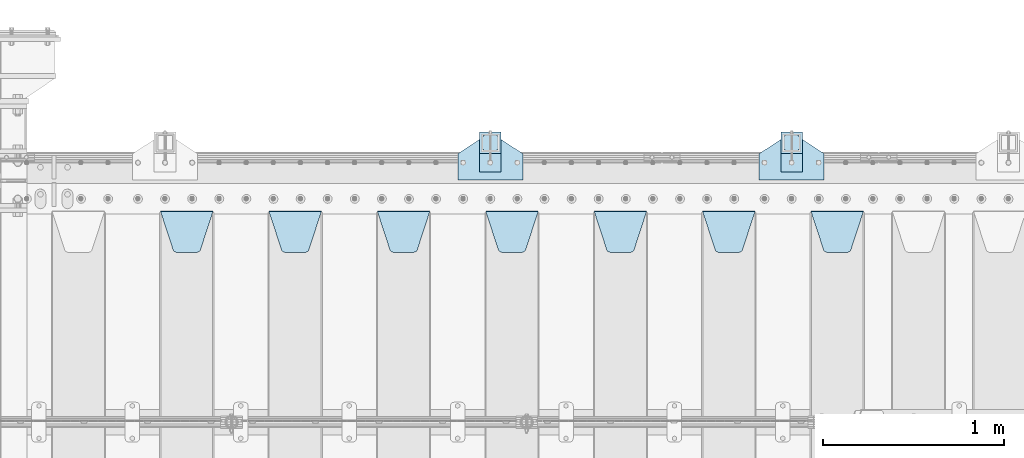
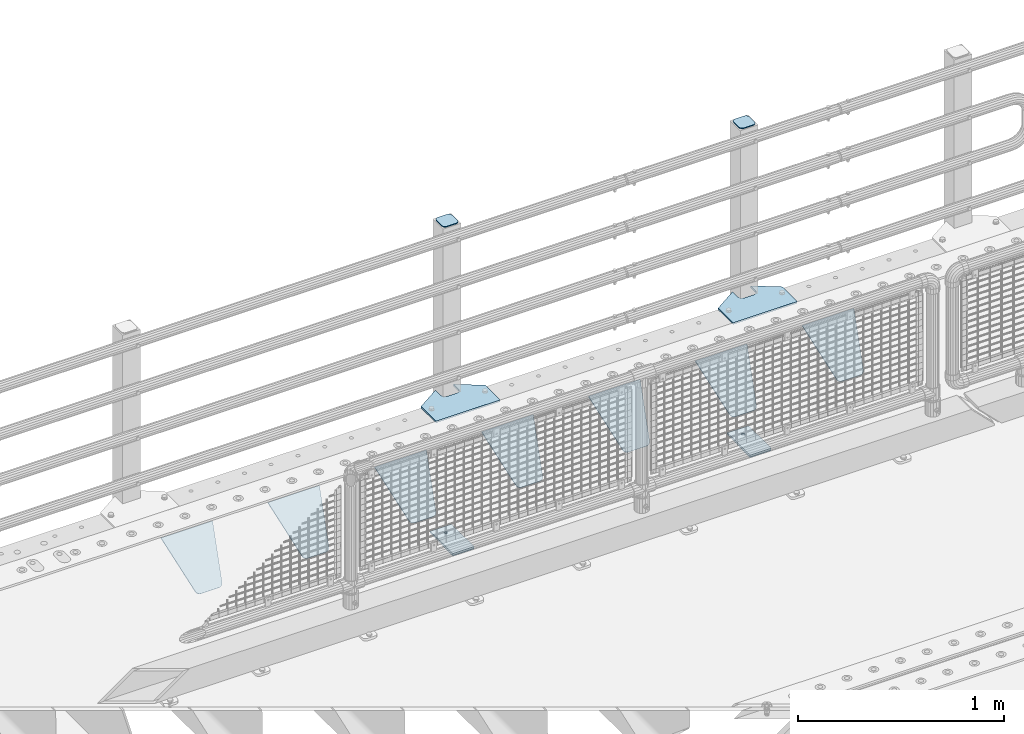
# One storey, part 224 of 242: 15 plates.
"""IFC2X3 building model written with IfcOpenShell, lengths in millimetres."""

from ifc_helpers import new_model, si_unit, frame, origin_with_axes, place, context, subcontext, project, spatial, faceted_brep, material, type_object, element, save


model = new_model("IFC2X3")

# Units and contexts
model_context = context("Model", 3, precision=1e-05, world=origin_with_axes())
body_context = subcontext(model_context, "Body", "Model", "MODEL_VIEW")
ifc_project = project(units=[si_unit("LENGTHUNIT", "METRE", prefix="MILLI"), si_unit("AREAUNIT", "SQUARE_METRE"), si_unit("VOLUMEUNIT", "CUBIC_METRE"), si_unit("MASSUNIT", "GRAM", prefix="KILO"), si_unit("TIMEUNIT", "SECOND"), si_unit("PLANEANGLEUNIT", "RADIAN"), si_unit("SOLIDANGLEUNIT", "STERADIAN"), si_unit("THERMODYNAMICTEMPERATUREUNIT", "DEGREE_CELSIUS"), si_unit("LUMINOUSINTENSITYUNIT", "LUMEN")], contexts=[model_context])

# Site, building, storey
site_placement = place(None, origin_with_axes())
site = spatial("IfcSite", under=ifc_project, at=site_placement, CompositionType="ELEMENT")
building_placement = place(site_placement, origin_with_axes())
building = spatial("IfcBuilding", under=site, at=building_placement, Name="Standard", CompositionType="ELEMENT")
storey_placement = place(building_placement, origin_with_axes())
storey = spatial("IfcBuildingStorey", under=building, at=storey_placement, Name="Undefined", CompositionType="ELEMENT", Elevation=0.0)

# Plates
ifc_material_1 = material(Name="STEEL/S355J2")
plate_type_1 = type_object("IfcPlateType", PredefinedType="NOTDEFINED")
plate_1_placement = place(storey_placement, frame((-24212.0, -17995.0, 5.00000000004911), z_axis=(0.0, 1.0, 0.0), x_axis=(1.0, 0.0, 0.0)))
element("IfcPlate", 1, at=plate_1_placement, inside=storey, type_object=plate_type_1, material=ifc_material_1, context=body_context, shape_type="Brep", body=[
    faceted_brep([(0.0, -5.0, 0.0), (2.31396552408114e-06, -5.0, 145.0), (2.31396552408114e-06, 5.0, 145.0), (0.0, 5.0, 0.0), (130.0, -5.0, 230.0), (130.0, 5.0, 230.0), (130.0, -5.0, 180.0), (130.0, 5.0, 180.0), (130.48036798992, -5.0, 175.122741949595), (130.48036798992, 5.0, 175.122741949595), (131.903011687216, -5.0, 170.432914190871), (131.903011687216, 5.0, 170.432914190871), (134.213259692435, -5.0, 166.110744174512), (134.213259692435, 5.0, 166.110744174512), (137.322330470335, -5.0, 162.322330470335), (137.322330470335, 5.0, 162.322330470335), (141.110744174512, -5.0, 159.213259692435), (141.110744174512, 5.0, 159.213259692435), (145.432914190871, -5.0, 156.903011687216), (145.432914190871, 5.0, 156.903011687216), (150.122741949595, -5.0, 155.48036798992), (150.122741949595, 5.0, 155.48036798992), (155.0, -5.0, 155.0), (155.0, 5.0, 155.0), (205.0, -5.0, 155.0), (205.0, 5.0, 155.0), (209.877258050405, -5.0, 155.48036798992), (209.877258050405, 5.0, 155.48036798992), (214.567085809129, -5.0, 156.903011687216), (214.567085809129, 5.0, 156.903011687216), (218.889255825488, -5.0, 159.213259692435), (218.889255825488, 5.0, 159.213259692435), (222.677669529665, -5.0, 162.322330470335), (222.677669529665, 5.0, 162.322330470335), (225.786740307565, -5.0, 166.110744174512), (225.786740307565, 5.0, 166.110744174512), (228.096988312784, -5.0, 170.432914190871), (228.096988312784, 5.0, 170.432914190871), (229.51963201008, -5.0, 175.122741949595), (229.51963201008, 5.0, 175.122741949595), (230.0, -5.0, 180.0), (230.0, 5.0, 180.0), (230.0, -5.0, 230.0), (230.0, 5.0, 230.0), (360.0, -5.0, 145.0), (360.0, 5.0, 145.0), (360.0, -5.0, -7.27595761418343e-12), (360.0, 5.0, -7.27595761418343e-12)], [[[0, 1, 2, 3]], [[1, 4, 5, 2]], [[4, 6, 7, 5]], [[6, 8, 9, 7]], [[8, 10, 11, 9]], [[10, 12, 13, 11]], [[12, 14, 15, 13]], [[14, 16, 17, 15]], [[16, 18, 19, 17]], [[18, 20, 21, 19]], [[20, 22, 23, 21]], [[22, 24, 25, 23]], [[24, 26, 27, 25]], [[26, 28, 29, 27]], [[28, 30, 31, 29]], [[30, 32, 33, 31]], [[32, 34, 35, 33]], [[34, 36, 37, 35]], [[36, 38, 39, 37]], [[38, 40, 41, 39]], [[40, 42, 43, 41]], [[42, 44, 45, 43]], [[44, 46, 47, 45]], [[46, 0, 3, 47]], [[5, 7, 9, 11, 13, 15, 17, 19, 21, 23, 25, 27, 29, 31, 33, 35, 37, 39, 41, 43, 45, 47, 3, 2]], [[46, 44, 42, 40, 38, 36, 34, 32, 30, 28, 26, 24, 22, 20, 18, 16, 14, 12, 10, 8, 6, 4, 1, 0]]]),
])
plate_2_placement = place(storey_placement, frame((-25880.0, -17995.0, 5.00000000004911), z_axis=(0.0, 1.0, 0.0), x_axis=(1.0, 0.0, 0.0)))
element("IfcPlate", 2, at=plate_2_placement, inside=storey, type_object=plate_type_1, material=ifc_material_1, context=body_context, shape_type="Brep", body=[
    faceted_brep([(0.0, -5.0, 0.0), (2.31396552408114e-06, -5.0, 145.0), (2.31396552408114e-06, 5.0, 145.0), (0.0, 5.0, 0.0), (130.0, -5.0, 230.0), (130.0, 5.0, 230.0), (130.0, -5.0, 180.0), (130.0, 5.0, 180.0), (130.48036798992, -5.0, 175.122741949595), (130.48036798992, 5.0, 175.122741949595), (131.903011687216, -5.0, 170.432914190871), (131.903011687216, 5.0, 170.432914190871), (134.213259692435, -5.0, 166.110744174512), (134.213259692435, 5.0, 166.110744174512), (137.322330470335, -5.0, 162.322330470335), (137.322330470335, 5.0, 162.322330470335), (141.110744174512, -5.0, 159.213259692435), (141.110744174512, 5.0, 159.213259692435), (145.432914190871, -5.0, 156.903011687216), (145.432914190871, 5.0, 156.903011687216), (150.122741949595, -5.0, 155.48036798992), (150.122741949595, 5.0, 155.48036798992), (155.0, -5.0, 155.0), (155.0, 5.0, 155.0), (205.0, -5.0, 155.0), (205.0, 5.0, 155.0), (209.877258050405, -5.0, 155.48036798992), (209.877258050405, 5.0, 155.48036798992), (214.567085809129, -5.0, 156.903011687216), (214.567085809129, 5.0, 156.903011687216), (218.889255825488, -5.0, 159.213259692435), (218.889255825488, 5.0, 159.213259692435), (222.677669529665, -5.0, 162.322330470335), (222.677669529665, 5.0, 162.322330470335), (225.786740307565, -5.0, 166.110744174512), (225.786740307565, 5.0, 166.110744174512), (228.096988312784, -5.0, 170.432914190871), (228.096988312784, 5.0, 170.432914190871), (229.51963201008, -5.0, 175.122741949595), (229.51963201008, 5.0, 175.122741949595), (230.0, -5.0, 180.0), (230.0, 5.0, 180.0), (230.0, -5.0, 230.0), (230.0, 5.0, 230.0), (360.0, -5.0, 145.0), (360.0, 5.0, 145.0), (360.0, -5.0, -7.27595761418343e-12), (360.0, 5.0, -7.27595761418343e-12)], [[[0, 1, 2, 3]], [[1, 4, 5, 2]], [[4, 6, 7, 5]], [[6, 8, 9, 7]], [[8, 10, 11, 9]], [[10, 12, 13, 11]], [[12, 14, 15, 13]], [[14, 16, 17, 15]], [[16, 18, 19, 17]], [[18, 20, 21, 19]], [[20, 22, 23, 21]], [[22, 24, 25, 23]], [[24, 26, 27, 25]], [[26, 28, 29, 27]], [[28, 30, 31, 29]], [[30, 32, 33, 31]], [[32, 34, 35, 33]], [[34, 36, 37, 35]], [[36, 38, 39, 37]], [[38, 40, 41, 39]], [[40, 42, 43, 41]], [[42, 44, 45, 43]], [[44, 46, 47, 45]], [[46, 0, 3, 47]], [[5, 7, 9, 11, 13, 15, 17, 19, 21, 23, 25, 27, 29, 31, 33, 35, 37, 39, 41, 43, 45, 47, 3, 2]], [[46, 44, 42, 40, 38, 36, 34, 32, 30, 28, 26, 24, 22, 20, 18, 16, 14, 12, 10, 8, 6, 4, 1, 0]]]),
])
plate_type_2 = type_object("IfcPlateType", PredefinedType="NOTDEFINED")
for number, where, z_axis, x_axis in (
    (3, (-24091.9999999999, -17949.9999999998, -850.000000000002), (0.0, 1.0, 0.0), (1.0, 0.0, 0.0)),
    (4, (-25759.9999999999, -17949.9999999998, -850.000000000002), (0.0, 1.0, 0.0), (1.0, 0.0, 0.0)),
):
    element("IfcPlate", number, at=place(storey_placement, frame(where, z_axis=z_axis, x_axis=x_axis)), inside=storey, type_object=plate_type_2, material=ifc_material_1, context=body_context, shape_type="Brep", body=[
        faceted_brep([(66.3639610305399, -5.0, 163.636038969114), (66.3639610305399, 5.0, 163.636038969114), (59.9999999998618, 5.0, 160.999999999793), (59.9999999998618, -5.0, 160.999999999793), (53.6360389691836, 5.0, 163.636038969114), (53.6360389691836, -5.0, 163.636038969114), (50.9999999998618, 5.0, 169.999999999793), (50.9999999998618, -5.0, 169.999999999793), (53.6360389691836, 5.0, 176.363961030471), (53.6360389691836, -5.0, 176.363961030471), (59.9999999998618, 5.0, 178.999999999793), (59.9999999998618, -5.0, 178.999999999793), (66.3639610305399, 5.0, 176.363961030471), (66.3639610305399, -5.0, 176.363961030471), (68.9999999998618, 5.0, 169.999999999793), (68.9999999998618, -5.0, 169.999999999793), (120.0, -5.0, 0.0), (120.0, -5.0, 220.0), (0.0, -5.0, 220.0), (0.0, -5.0, 0.0), (0.0, 5.0, 0.0), (120.0, 5.0, 0.0), (120.0, 5.0, 220.0), (0.0, 5.0, 220.0)], [[[0, 1, 2, 3]], [[3, 2, 4, 5]], [[5, 4, 6, 7]], [[7, 6, 8, 9]], [[9, 8, 10, 11]], [[11, 10, 12, 13]], [[13, 12, 14, 15]], [[15, 14, 1, 0]], [[16, 17, 18, 19], [11, 13, 15, 0, 3, 5, 7, 9]], [[16, 19, 20, 21]], [[17, 16, 21, 22]], [[18, 17, 22, 23]], [[19, 18, 23, 20]], [[22, 21, 20, 23], [2, 1, 14, 12, 10, 8, 6, 4]]]),
    ])
plate_type_3 = type_object("IfcPlateType", PredefinedType="NOTDEFINED")
plate_3_placement = place(storey_placement, frame((-23987.9999999999, -17833.9999999998, 1012.50000000001), z_axis=(0.0, 1.0, 0.0), x_axis=(-1.0, 0.0, 0.0)))
element("IfcPlate", 5, at=plate_3_placement, inside=storey, type_object=plate_type_3, material=ifc_material_1, context=body_context, shape_type="Brep", body=[
    faceted_brep([(0.0, -2.5, 19.0), (0.0, -2.5, 69.0), (0.0, 2.5, 69.0), (0.0, 2.5, 19.0), (0.476369668544066, -2.5, 73.2278977451715), (0.476369668544066, 2.5, 73.2278977451715), (1.88159150985302, -2.5, 77.2437910432345), (1.88159150985302, 2.5, 77.2437910432345), (4.14520183310742, -2.5, 80.8463062353148), (4.14520183310742, 2.5, 80.8463062353148), (7.15369376468516, -2.5, 83.8547981668926), (7.15369376468516, 2.5, 83.8547981668926), (10.7562089567655, -2.5, 86.118408490147), (10.7562089567655, 2.5, 86.118408490147), (14.7721022548285, -2.5, 87.5236303314559), (14.7721022548285, 2.5, 87.5236303314559), (19.0, -2.5, 88.0), (19.0, 2.5, 88.0), (69.0, -2.5, 88.0), (69.0, 2.5, 88.0), (73.2278977451715, -2.5, 87.5236303314559), (73.2278977451715, 2.5, 87.5236303314559), (77.2437910432345, -2.5, 86.118408490147), (77.2437910432345, 2.5, 86.118408490147), (80.8463062353148, -2.5, 83.8547981668926), (80.8463062353148, 2.5, 83.8547981668926), (83.8547981668926, -2.5, 80.8463062353148), (83.8547981668926, 2.5, 80.8463062353148), (86.118408490147, -2.5, 77.2437910432345), (86.118408490147, 2.5, 77.2437910432345), (87.5236303314559, -2.5, 73.2278977451715), (87.5236303314559, 2.5, 73.2278977451715), (88.0, -2.5, 69.0), (88.0, 2.5, 69.0), (88.0, -2.5, 19.0), (88.0, 2.5, 19.0), (87.5236303314559, -2.5, 14.7721022548285), (87.5236303314559, 2.5, 14.7721022548285), (86.118408490147, -2.5, 10.7562089567655), (86.118408490147, 2.5, 10.7562089567655), (83.8547981668926, -2.5, 7.15369376468516), (83.8547981668926, 2.5, 7.15369376468516), (80.8463062353148, -2.5, 4.14520183310742), (80.8463062353148, 2.5, 4.14520183310742), (77.2437910432345, -2.5, 1.88159150985302), (77.2437910432345, 2.5, 1.88159150985302), (73.2278977451715, -2.5, 0.476369668544066), (73.2278977451715, 2.5, 0.476369668544066), (69.0, -2.5, 0.0), (69.0, 2.5, 0.0), (19.0, -2.5, 0.0), (19.0, 2.5, 0.0), (14.7721022548285, -2.5, 0.476369668544066), (14.7721022548285, 2.5, 0.476369668544066), (10.7562089567655, -2.5, 1.88159150985302), (10.7562089567655, 2.5, 1.88159150985302), (7.15369376468516, -2.5, 4.14520183310742), (7.15369376468516, 2.5, 4.14520183310742), (4.14520183310742, -2.5, 7.15369376468516), (4.14520183310742, 2.5, 7.15369376468516), (1.88159150985302, -2.5, 10.7562089567655), (1.88159150985302, 2.5, 10.7562089567655), (0.476369668544066, -2.5, 14.7721022548285), (0.476369668544066, 2.5, 14.7721022548285)], [[[0, 1, 2, 3]], [[1, 4, 5, 2]], [[4, 6, 7, 5]], [[6, 8, 9, 7]], [[8, 10, 11, 9]], [[10, 12, 13, 11]], [[12, 14, 15, 13]], [[14, 16, 17, 15]], [[16, 18, 19, 17]], [[18, 20, 21, 19]], [[20, 22, 23, 21]], [[22, 24, 25, 23]], [[24, 26, 27, 25]], [[26, 28, 29, 27]], [[28, 30, 31, 29]], [[30, 32, 33, 31]], [[32, 34, 35, 33]], [[34, 36, 37, 35]], [[36, 38, 39, 37]], [[38, 40, 41, 39]], [[40, 42, 43, 41]], [[42, 44, 45, 43]], [[44, 46, 47, 45]], [[46, 48, 49, 47]], [[48, 50, 51, 49]], [[50, 52, 53, 51]], [[52, 54, 55, 53]], [[54, 56, 57, 55]], [[56, 58, 59, 57]], [[58, 60, 61, 59]], [[60, 62, 63, 61]], [[62, 0, 3, 63]], [[5, 7, 9, 11, 13, 15, 17, 19, 21, 23, 25, 27, 29, 31, 33, 35, 37, 39, 41, 43, 45, 47, 49, 51, 53, 55, 57, 59, 61, 63, 3, 2]], [[62, 60, 58, 56, 54, 52, 50, 48, 46, 44, 42, 40, 38, 36, 34, 32, 30, 28, 26, 24, 22, 20, 18, 16, 14, 12, 10, 8, 6, 4, 1, 0]]]),
])
plate_4_placement = place(storey_placement, frame((-25655.9999999999, -17833.9999999998, 1012.50000000001), z_axis=(0.0, 1.0, 0.0), x_axis=(-1.0, 0.0, 0.0)))
element("IfcPlate", 6, at=plate_4_placement, inside=storey, type_object=plate_type_3, material=ifc_material_1, context=body_context, shape_type="Brep", body=[
    faceted_brep([(0.0, -2.5, 19.0), (0.0, -2.5, 69.0), (0.0, 2.5, 69.0), (0.0, 2.5, 19.0), (0.476369668544066, -2.5, 73.2278977451715), (0.476369668544066, 2.5, 73.2278977451715), (1.88159150985302, -2.5, 77.2437910432345), (1.88159150985302, 2.5, 77.2437910432345), (4.14520183310742, -2.5, 80.8463062353148), (4.14520183310742, 2.5, 80.8463062353148), (7.15369376468516, -2.5, 83.8547981668926), (7.15369376468516, 2.5, 83.8547981668926), (10.7562089567655, -2.5, 86.118408490147), (10.7562089567655, 2.5, 86.118408490147), (14.7721022548285, -2.5, 87.5236303314559), (14.7721022548285, 2.5, 87.5236303314559), (19.0, -2.5, 88.0), (19.0, 2.5, 88.0), (69.0, -2.5, 88.0), (69.0, 2.5, 88.0), (73.2278977451715, -2.5, 87.5236303314559), (73.2278977451715, 2.5, 87.5236303314559), (77.2437910432345, -2.5, 86.118408490147), (77.2437910432345, 2.5, 86.118408490147), (80.8463062353148, -2.5, 83.8547981668926), (80.8463062353148, 2.5, 83.8547981668926), (83.8547981668926, -2.5, 80.8463062353148), (83.8547981668926, 2.5, 80.8463062353148), (86.118408490147, -2.5, 77.2437910432345), (86.118408490147, 2.5, 77.2437910432345), (87.5236303314559, -2.5, 73.2278977451715), (87.5236303314559, 2.5, 73.2278977451715), (88.0, -2.5, 69.0), (88.0, 2.5, 69.0), (88.0, -2.5, 19.0), (88.0, 2.5, 19.0), (87.5236303314559, -2.5, 14.7721022548285), (87.5236303314559, 2.5, 14.7721022548285), (86.118408490147, -2.5, 10.7562089567655), (86.118408490147, 2.5, 10.7562089567655), (83.8547981668926, -2.5, 7.15369376468516), (83.8547981668926, 2.5, 7.15369376468516), (80.8463062353148, -2.5, 4.14520183310742), (80.8463062353148, 2.5, 4.14520183310742), (77.2437910432345, -2.5, 1.88159150985302), (77.2437910432345, 2.5, 1.88159150985302), (73.2278977451715, -2.5, 0.476369668544066), (73.2278977451715, 2.5, 0.476369668544066), (69.0, -2.5, 0.0), (69.0, 2.5, 0.0), (19.0, -2.5, 0.0), (19.0, 2.5, 0.0), (14.7721022548285, -2.5, 0.476369668544066), (14.7721022548285, 2.5, 0.476369668544066), (10.7562089567655, -2.5, 1.88159150985302), (10.7562089567655, 2.5, 1.88159150985302), (7.15369376468516, -2.5, 4.14520183310742), (7.15369376468516, 2.5, 4.14520183310742), (4.14520183310742, -2.5, 7.15369376468516), (4.14520183310742, 2.5, 7.15369376468516), (1.88159150985302, -2.5, 10.7562089567655), (1.88159150985302, 2.5, 10.7562089567655), (0.476369668544066, -2.5, 14.7721022548285), (0.476369668544066, 2.5, 14.7721022548285)], [[[0, 1, 2, 3]], [[1, 4, 5, 2]], [[4, 6, 7, 5]], [[6, 8, 9, 7]], [[8, 10, 11, 9]], [[10, 12, 13, 11]], [[12, 14, 15, 13]], [[14, 16, 17, 15]], [[16, 18, 19, 17]], [[18, 20, 21, 19]], [[20, 22, 23, 21]], [[22, 24, 25, 23]], [[24, 26, 27, 25]], [[26, 28, 29, 27]], [[28, 30, 31, 29]], [[30, 32, 33, 31]], [[32, 34, 35, 33]], [[34, 36, 37, 35]], [[36, 38, 39, 37]], [[38, 40, 41, 39]], [[40, 42, 43, 41]], [[42, 44, 45, 43]], [[44, 46, 47, 45]], [[46, 48, 49, 47]], [[48, 50, 51, 49]], [[50, 52, 53, 51]], [[52, 54, 55, 53]], [[54, 56, 57, 55]], [[56, 58, 59, 57]], [[58, 60, 61, 59]], [[60, 62, 63, 61]], [[62, 0, 3, 63]], [[5, 7, 9, 11, 13, 15, 17, 19, 21, 23, 25, 27, 29, 31, 33, 35, 37, 39, 41, 43, 45, 47, 49, 51, 53, 55, 57, 59, 61, 63, 3, 2]], [[62, 60, 58, 56, 54, 52, 50, 48, 46, 44, 42, 40, 38, 36, 34, 32, 30, 28, 26, 24, 22, 20, 18, 16, 14, 12, 10, 8, 6, 4, 1, 0]]]),
])
plate_type_4 = type_object("IfcPlateType", PredefinedType="NOTDEFINED")
for number, where, z_axis, x_axis in (
    (7, (-24091.9999999999, -17949.9999999998, -857.500000000002), (0.0, 1.0, 0.0), (1.0, 0.0, 0.0)),
    (8, (-25759.9999999999, -17949.9999999998, -857.500000000002), (0.0, 1.0, 0.0), (1.0, 0.0, 0.0)),
):
    element("IfcPlate", number, at=place(storey_placement, frame(where, z_axis=z_axis, x_axis=x_axis)), inside=storey, type_object=plate_type_4, material=ifc_material_1, context=body_context, shape_type="Brep", body=[
        faceted_brep([(0.0, -2.5, 0.0), (0.0, -2.5, 100.0), (0.0, 2.5, 100.0), (0.0, 2.5, 0.0), (120.0, -2.5, 100.0), (120.0, 2.5, 100.0), (120.0, -2.5, 0.0), (120.0, 2.5, 0.0)], [[[0, 1, 2, 3]], [[1, 4, 5, 2]], [[4, 6, 7, 5]], [[6, 0, 3, 7]], [[5, 7, 3, 2]], [[6, 4, 1, 0]]]),
    ])
ifc_material_2 = material(Name="STEEL/S355N")
plate_type_5 = type_object("IfcPlateType", PredefinedType="NOTDEFINED")
plate_5_placement = place(storey_placement, frame((-23925.0, -18168.2322330441, -1.76776695296576), z_axis=(0.0, -0.707106781186547, -0.707106781186548), x_axis=(1.0, 0.0, 0.0)))
element("IfcPlate", 9, at=plate_5_placement, inside=storey, type_object=plate_type_5, material=ifc_material_2, context=body_context, shape_type="Brep", body=[
    faceted_brep([(0.0, -2.5, 0.0), (69.345504679477, -2.50000000000182, 300.171731424829), (69.345504679477, 2.5, 300.171731424829), (0.0, 2.5, 0.0), (70.9274061199576, -2.5, 304.897442415398), (70.9274061199576, 2.5, 304.897442415398), (73.3818627772307, -2.5, 309.234538108525), (73.3818627772307, 2.50000000000182, 309.234538108529), (76.6187032999551, -2.5, 313.023683126101), (76.6187032999551, 2.50000000000182, 313.023683126103), (80.5190132704993, -2.5, 316.12567259537), (80.5190132704993, 2.5, 316.12567259537), (84.9395038596849, -2.5, 318.426546230474), (84.9395038596849, 2.50000000000182, 318.426546230476), (89.7177759439219, -2.49999999999818, 319.841774983273), (89.7177759439219, 2.50000000000182, 319.841774983273), (94.678286292652, -2.5, 320.319366455076), (94.678286292652, 2.5, 320.319366455076), (195.321713707348, -2.5, 320.319366455076), (195.321713707348, 2.5, 320.319366455076), (200.282224056078, -2.5, 319.841774983272), (200.282224056078, 2.50000000000182, 319.841774983273), (205.060496140315, -2.5, 318.426546230474), (205.060496140315, 2.49999999999818, 318.426546230474), (209.480986729501, -2.49999999999818, 316.12567259537), (209.480986729501, 2.5, 316.12567259537), (213.381296700045, -2.5, 313.023683126101), (213.381296700045, 2.49999999999818, 313.023683126101), (216.618137222769, -2.5, 309.234538108525), (216.618137222769, 2.5, 309.234538108523), (219.072593880042, -2.49999999999818, 304.897442415398), (219.072593880042, 2.50000000000182, 304.897442415398), (220.654495320523, -2.50000000000182, 300.171731424829), (220.654495320523, 2.5, 300.171731424829), (290.0, -2.5, 0.0), (290.0, 2.5, -1.81898940354586e-12)], [[[0, 1, 2, 3]], [[1, 4, 5, 2]], [[4, 6, 7, 5]], [[6, 8, 9, 7]], [[8, 10, 11, 9]], [[10, 12, 13, 11]], [[12, 14, 15, 13]], [[14, 16, 17, 15]], [[16, 18, 19, 17]], [[18, 20, 21, 19]], [[20, 22, 23, 21]], [[22, 24, 25, 23]], [[24, 26, 27, 25]], [[26, 28, 29, 27]], [[28, 30, 31, 29]], [[30, 32, 33, 31]], [[32, 34, 35, 33]], [[34, 0, 3, 35]], [[5, 7, 9, 11, 13, 15, 17, 19, 21, 23, 25, 27, 29, 31, 33, 35, 3, 2]], [[34, 32, 30, 28, 26, 24, 22, 20, 18, 16, 14, 12, 10, 8, 6, 4, 1, 0]]]),
])
plate_6_placement = place(storey_placement, frame((-24525.0, -18168.2322330441, -1.76776695296576), z_axis=(0.0, -0.707106781186547, -0.707106781186548), x_axis=(1.0, 0.0, 0.0)))
element("IfcPlate", 10, at=plate_6_placement, inside=storey, type_object=plate_type_5, material=ifc_material_2, context=body_context, shape_type="Brep", body=[
    faceted_brep([(0.0, -2.5, 0.0), (69.345504679477, -2.50000000000182, 300.171731424829), (69.345504679477, 2.5, 300.171731424829), (0.0, 2.5, 0.0), (70.9274061199576, -2.5, 304.897442415398), (70.9274061199576, 2.5, 304.897442415398), (73.3818627772307, -2.5, 309.234538108525), (73.3818627772307, 2.50000000000182, 309.234538108529), (76.6187032999551, -2.5, 313.023683126101), (76.6187032999551, 2.50000000000182, 313.023683126103), (80.5190132704993, -2.5, 316.12567259537), (80.5190132704993, 2.5, 316.12567259537), (84.9395038596849, -2.5, 318.426546230474), (84.9395038596849, 2.50000000000182, 318.426546230476), (89.7177759439219, -2.49999999999818, 319.841774983273), (89.7177759439219, 2.50000000000182, 319.841774983273), (94.678286292652, -2.5, 320.319366455076), (94.678286292652, 2.5, 320.319366455076), (195.321713707348, -2.5, 320.319366455076), (195.321713707348, 2.5, 320.319366455076), (200.282224056078, -2.5, 319.841774983272), (200.282224056078, 2.50000000000182, 319.841774983273), (205.060496140315, -2.5, 318.426546230474), (205.060496140315, 2.49999999999818, 318.426546230474), (209.480986729501, -2.49999999999818, 316.12567259537), (209.480986729501, 2.5, 316.12567259537), (213.381296700045, -2.5, 313.023683126101), (213.381296700045, 2.49999999999818, 313.023683126101), (216.618137222769, -2.5, 309.234538108525), (216.618137222769, 2.5, 309.234538108523), (219.072593880042, -2.49999999999818, 304.897442415398), (219.072593880042, 2.50000000000182, 304.897442415398), (220.654495320523, -2.50000000000182, 300.171731424829), (220.654495320523, 2.5, 300.171731424829), (290.0, -2.5, 0.0), (290.0, 2.5, -1.81898940354586e-12)], [[[0, 1, 2, 3]], [[1, 4, 5, 2]], [[4, 6, 7, 5]], [[6, 8, 9, 7]], [[8, 10, 11, 9]], [[10, 12, 13, 11]], [[12, 14, 15, 13]], [[14, 16, 17, 15]], [[16, 18, 19, 17]], [[18, 20, 21, 19]], [[20, 22, 23, 21]], [[22, 24, 25, 23]], [[24, 26, 27, 25]], [[26, 28, 29, 27]], [[28, 30, 31, 29]], [[30, 32, 33, 31]], [[32, 34, 35, 33]], [[34, 0, 3, 35]], [[5, 7, 9, 11, 13, 15, 17, 19, 21, 23, 25, 27, 29, 31, 33, 35, 3, 2]], [[34, 32, 30, 28, 26, 24, 22, 20, 18, 16, 14, 12, 10, 8, 6, 4, 1, 0]]]),
])
plate_7_placement = place(storey_placement, frame((-25125.0, -18168.2322330441, -1.76776695296576), z_axis=(0.0, -0.707106781186547, -0.707106781186548), x_axis=(1.0, 0.0, 0.0)))
element("IfcPlate", 11, at=plate_7_placement, inside=storey, type_object=plate_type_5, material=ifc_material_2, context=body_context, shape_type="Brep", body=[
    faceted_brep([(0.0, -2.5, 0.0), (69.345504679477, -2.50000000000182, 300.171731424829), (69.345504679477, 2.5, 300.171731424829), (0.0, 2.5, 0.0), (70.9274061199576, -2.5, 304.897442415398), (70.9274061199576, 2.5, 304.897442415398), (73.3818627772307, -2.5, 309.234538108525), (73.3818627772307, 2.50000000000182, 309.234538108529), (76.6187032999551, -2.5, 313.023683126101), (76.6187032999551, 2.50000000000182, 313.023683126103), (80.5190132704993, -2.5, 316.12567259537), (80.5190132704993, 2.5, 316.12567259537), (84.9395038596849, -2.5, 318.426546230474), (84.9395038596849, 2.50000000000182, 318.426546230476), (89.7177759439219, -2.49999999999818, 319.841774983273), (89.7177759439219, 2.50000000000182, 319.841774983273), (94.678286292652, -2.5, 320.319366455076), (94.678286292652, 2.5, 320.319366455076), (195.321713707348, -2.5, 320.319366455076), (195.321713707348, 2.5, 320.319366455076), (200.282224056078, -2.5, 319.841774983272), (200.282224056078, 2.50000000000182, 319.841774983273), (205.060496140315, -2.5, 318.426546230474), (205.060496140315, 2.49999999999818, 318.426546230474), (209.480986729501, -2.49999999999818, 316.12567259537), (209.480986729501, 2.5, 316.12567259537), (213.381296700045, -2.5, 313.023683126101), (213.381296700045, 2.49999999999818, 313.023683126101), (216.618137222769, -2.5, 309.234538108525), (216.618137222769, 2.5, 309.234538108523), (219.072593880042, -2.49999999999818, 304.897442415398), (219.072593880042, 2.50000000000182, 304.897442415398), (220.654495320523, -2.50000000000182, 300.171731424829), (220.654495320523, 2.5, 300.171731424829), (290.0, -2.5, 0.0), (290.0, 2.5, -1.81898940354586e-12)], [[[0, 1, 2, 3]], [[1, 4, 5, 2]], [[4, 6, 7, 5]], [[6, 8, 9, 7]], [[8, 10, 11, 9]], [[10, 12, 13, 11]], [[12, 14, 15, 13]], [[14, 16, 17, 15]], [[16, 18, 19, 17]], [[18, 20, 21, 19]], [[20, 22, 23, 21]], [[22, 24, 25, 23]], [[24, 26, 27, 25]], [[26, 28, 29, 27]], [[28, 30, 31, 29]], [[30, 32, 33, 31]], [[32, 34, 35, 33]], [[34, 0, 3, 35]], [[5, 7, 9, 11, 13, 15, 17, 19, 21, 23, 25, 27, 29, 31, 33, 35, 3, 2]], [[34, 32, 30, 28, 26, 24, 22, 20, 18, 16, 14, 12, 10, 8, 6, 4, 1, 0]]]),
])
plate_8_placement = place(storey_placement, frame((-25725.0, -18168.2322330441, -1.76776695296576), z_axis=(0.0, -0.707106781186547, -0.707106781186548), x_axis=(1.0, 0.0, 0.0)))
element("IfcPlate", 12, at=plate_8_placement, inside=storey, type_object=plate_type_5, material=ifc_material_2, context=body_context, shape_type="Brep", body=[
    faceted_brep([(0.0, -2.5, 0.0), (69.345504679477, -2.50000000000182, 300.171731424829), (69.345504679477, 2.5, 300.171731424829), (0.0, 2.5, 0.0), (70.9274061199576, -2.5, 304.897442415398), (70.9274061199576, 2.5, 304.897442415398), (73.3818627772307, -2.5, 309.234538108525), (73.3818627772307, 2.50000000000182, 309.234538108529), (76.6187032999551, -2.5, 313.023683126101), (76.6187032999551, 2.50000000000182, 313.023683126103), (80.5190132704993, -2.5, 316.12567259537), (80.5190132704993, 2.5, 316.12567259537), (84.9395038596849, -2.5, 318.426546230474), (84.9395038596849, 2.50000000000182, 318.426546230476), (89.7177759439219, -2.49999999999818, 319.841774983273), (89.7177759439219, 2.50000000000182, 319.841774983273), (94.678286292652, -2.5, 320.319366455076), (94.678286292652, 2.5, 320.319366455076), (195.321713707348, -2.5, 320.319366455076), (195.321713707348, 2.5, 320.319366455076), (200.282224056078, -2.5, 319.841774983272), (200.282224056078, 2.50000000000182, 319.841774983273), (205.060496140315, -2.5, 318.426546230474), (205.060496140315, 2.49999999999818, 318.426546230474), (209.480986729501, -2.49999999999818, 316.12567259537), (209.480986729501, 2.5, 316.12567259537), (213.381296700045, -2.5, 313.023683126101), (213.381296700045, 2.49999999999818, 313.023683126101), (216.618137222769, -2.5, 309.234538108525), (216.618137222769, 2.5, 309.234538108523), (219.072593880042, -2.49999999999818, 304.897442415398), (219.072593880042, 2.50000000000182, 304.897442415398), (220.654495320523, -2.50000000000182, 300.171731424829), (220.654495320523, 2.5, 300.171731424829), (290.0, -2.5, 0.0), (290.0, 2.5, -1.81898940354586e-12)], [[[0, 1, 2, 3]], [[1, 4, 5, 2]], [[4, 6, 7, 5]], [[6, 8, 9, 7]], [[8, 10, 11, 9]], [[10, 12, 13, 11]], [[12, 14, 15, 13]], [[14, 16, 17, 15]], [[16, 18, 19, 17]], [[18, 20, 21, 19]], [[20, 22, 23, 21]], [[22, 24, 25, 23]], [[24, 26, 27, 25]], [[26, 28, 29, 27]], [[28, 30, 31, 29]], [[30, 32, 33, 31]], [[32, 34, 35, 33]], [[34, 0, 3, 35]], [[5, 7, 9, 11, 13, 15, 17, 19, 21, 23, 25, 27, 29, 31, 33, 35, 3, 2]], [[34, 32, 30, 28, 26, 24, 22, 20, 18, 16, 14, 12, 10, 8, 6, 4, 1, 0]]]),
])
plate_9_placement = place(storey_placement, frame((-26325.0, -18168.2322330441, -1.76776695296576), z_axis=(0.0, -0.707106781186547, -0.707106781186548), x_axis=(1.0, 0.0, 0.0)))
element("IfcPlate", 13, at=plate_9_placement, inside=storey, type_object=plate_type_5, material=ifc_material_2, context=body_context, shape_type="Brep", body=[
    faceted_brep([(0.0, -2.5, 0.0), (69.345504679477, -2.50000000000182, 300.171731424829), (69.345504679477, 2.5, 300.171731424829), (0.0, 2.5, 0.0), (70.9274061199576, -2.5, 304.897442415398), (70.9274061199576, 2.5, 304.897442415398), (73.3818627772307, -2.5, 309.234538108525), (73.3818627772307, 2.50000000000182, 309.234538108529), (76.6187032999551, -2.5, 313.023683126101), (76.6187032999551, 2.50000000000182, 313.023683126103), (80.5190132704993, -2.5, 316.12567259537), (80.5190132704993, 2.5, 316.12567259537), (84.9395038596849, -2.5, 318.426546230474), (84.9395038596849, 2.50000000000182, 318.426546230476), (89.7177759439219, -2.49999999999818, 319.841774983273), (89.7177759439219, 2.50000000000182, 319.841774983273), (94.678286292652, -2.5, 320.319366455076), (94.678286292652, 2.5, 320.319366455076), (195.321713707348, -2.5, 320.319366455076), (195.321713707348, 2.5, 320.319366455076), (200.282224056078, -2.5, 319.841774983272), (200.282224056078, 2.50000000000182, 319.841774983273), (205.060496140315, -2.5, 318.426546230474), (205.060496140315, 2.49999999999818, 318.426546230474), (209.480986729501, -2.49999999999818, 316.12567259537), (209.480986729501, 2.5, 316.12567259537), (213.381296700045, -2.5, 313.023683126101), (213.381296700045, 2.49999999999818, 313.023683126101), (216.618137222769, -2.5, 309.234538108525), (216.618137222769, 2.5, 309.234538108523), (219.072593880042, -2.49999999999818, 304.897442415398), (219.072593880042, 2.50000000000182, 304.897442415398), (220.654495320523, -2.50000000000182, 300.171731424829), (220.654495320523, 2.5, 300.171731424829), (290.0, -2.5, 0.0), (290.0, 2.5, -1.81898940354586e-12)], [[[0, 1, 2, 3]], [[1, 4, 5, 2]], [[4, 6, 7, 5]], [[6, 8, 9, 7]], [[8, 10, 11, 9]], [[10, 12, 13, 11]], [[12, 14, 15, 13]], [[14, 16, 17, 15]], [[16, 18, 19, 17]], [[18, 20, 21, 19]], [[20, 22, 23, 21]], [[22, 24, 25, 23]], [[24, 26, 27, 25]], [[26, 28, 29, 27]], [[28, 30, 31, 29]], [[30, 32, 33, 31]], [[32, 34, 35, 33]], [[34, 0, 3, 35]], [[5, 7, 9, 11, 13, 15, 17, 19, 21, 23, 25, 27, 29, 31, 33, 35, 3, 2]], [[34, 32, 30, 28, 26, 24, 22, 20, 18, 16, 14, 12, 10, 8, 6, 4, 1, 0]]]),
])
plate_10_placement = place(storey_placement, frame((-26925.0, -18168.2322330441, -1.76776695296576), z_axis=(0.0, -0.707106781186547, -0.707106781186548), x_axis=(1.0, 0.0, 0.0)))
element("IfcPlate", 14, at=plate_10_placement, inside=storey, type_object=plate_type_5, material=ifc_material_2, context=body_context, shape_type="Brep", body=[
    faceted_brep([(0.0, -2.5, 0.0), (69.345504679477, -2.50000000000182, 300.171731424829), (69.345504679477, 2.5, 300.171731424829), (0.0, 2.5, 0.0), (70.9274061199576, -2.5, 304.897442415398), (70.9274061199576, 2.5, 304.897442415398), (73.3818627772307, -2.5, 309.234538108525), (73.3818627772307, 2.50000000000182, 309.234538108529), (76.6187032999551, -2.5, 313.023683126101), (76.6187032999551, 2.50000000000182, 313.023683126103), (80.5190132704993, -2.5, 316.12567259537), (80.5190132704993, 2.5, 316.12567259537), (84.9395038596849, -2.5, 318.426546230474), (84.9395038596849, 2.50000000000182, 318.426546230476), (89.7177759439219, -2.49999999999818, 319.841774983273), (89.7177759439219, 2.50000000000182, 319.841774983273), (94.678286292652, -2.5, 320.319366455076), (94.678286292652, 2.5, 320.319366455076), (195.321713707348, -2.5, 320.319366455076), (195.321713707348, 2.5, 320.319366455076), (200.282224056078, -2.5, 319.841774983272), (200.282224056078, 2.50000000000182, 319.841774983273), (205.060496140315, -2.5, 318.426546230474), (205.060496140315, 2.49999999999818, 318.426546230474), (209.480986729501, -2.49999999999818, 316.12567259537), (209.480986729501, 2.5, 316.12567259537), (213.381296700045, -2.5, 313.023683126101), (213.381296700045, 2.49999999999818, 313.023683126101), (216.618137222769, -2.5, 309.234538108525), (216.618137222769, 2.5, 309.234538108523), (219.072593880042, -2.49999999999818, 304.897442415398), (219.072593880042, 2.50000000000182, 304.897442415398), (220.654495320523, -2.50000000000182, 300.171731424829), (220.654495320523, 2.5, 300.171731424829), (290.0, -2.5, 0.0), (290.0, 2.5, -1.81898940354586e-12)], [[[0, 1, 2, 3]], [[1, 4, 5, 2]], [[4, 6, 7, 5]], [[6, 8, 9, 7]], [[8, 10, 11, 9]], [[10, 12, 13, 11]], [[12, 14, 15, 13]], [[14, 16, 17, 15]], [[16, 18, 19, 17]], [[18, 20, 21, 19]], [[20, 22, 23, 21]], [[22, 24, 25, 23]], [[24, 26, 27, 25]], [[26, 28, 29, 27]], [[28, 30, 31, 29]], [[30, 32, 33, 31]], [[32, 34, 35, 33]], [[34, 0, 3, 35]], [[5, 7, 9, 11, 13, 15, 17, 19, 21, 23, 25, 27, 29, 31, 33, 35, 3, 2]], [[34, 32, 30, 28, 26, 24, 22, 20, 18, 16, 14, 12, 10, 8, 6, 4, 1, 0]]]),
])
plate_11_placement = place(storey_placement, frame((-27525.0, -18168.2322330441, -1.76776695296576), z_axis=(0.0, -0.707106781186547, -0.707106781186548), x_axis=(1.0, 0.0, 0.0)))
element("IfcPlate", 15, at=plate_11_placement, inside=storey, type_object=plate_type_5, material=ifc_material_2, context=body_context, shape_type="Brep", body=[
    faceted_brep([(0.0, -2.5, 0.0), (69.345504679477, -2.50000000000182, 300.171731424829), (69.345504679477, 2.5, 300.171731424829), (0.0, 2.5, 0.0), (70.9274061199576, -2.5, 304.897442415398), (70.9274061199576, 2.5, 304.897442415398), (73.3818627772307, -2.5, 309.234538108525), (73.3818627772307, 2.50000000000182, 309.234538108529), (76.6187032999551, -2.5, 313.023683126101), (76.6187032999551, 2.50000000000182, 313.023683126103), (80.5190132704993, -2.5, 316.12567259537), (80.5190132704993, 2.5, 316.12567259537), (84.9395038596849, -2.5, 318.426546230474), (84.9395038596849, 2.50000000000182, 318.426546230476), (89.7177759439219, -2.49999999999818, 319.841774983273), (89.7177759439219, 2.50000000000182, 319.841774983273), (94.678286292652, -2.5, 320.319366455076), (94.678286292652, 2.5, 320.319366455076), (195.321713707348, -2.5, 320.319366455076), (195.321713707348, 2.5, 320.319366455076), (200.282224056078, -2.5, 319.841774983272), (200.282224056078, 2.50000000000182, 319.841774983273), (205.060496140315, -2.5, 318.426546230474), (205.060496140315, 2.49999999999818, 318.426546230474), (209.480986729501, -2.49999999999818, 316.12567259537), (209.480986729501, 2.5, 316.12567259537), (213.381296700045, -2.5, 313.023683126101), (213.381296700045, 2.49999999999818, 313.023683126101), (216.618137222769, -2.5, 309.234538108525), (216.618137222769, 2.5, 309.234538108523), (219.072593880042, -2.49999999999818, 304.897442415398), (219.072593880042, 2.50000000000182, 304.897442415398), (220.654495320523, -2.50000000000182, 300.171731424829), (220.654495320523, 2.5, 300.171731424829), (290.0, -2.5, 0.0), (290.0, 2.5, -1.81898940354586e-12)], [[[0, 1, 2, 3]], [[1, 4, 5, 2]], [[4, 6, 7, 5]], [[6, 8, 9, 7]], [[8, 10, 11, 9]], [[10, 12, 13, 11]], [[12, 14, 15, 13]], [[14, 16, 17, 15]], [[16, 18, 19, 17]], [[18, 20, 21, 19]], [[20, 22, 23, 21]], [[22, 24, 25, 23]], [[24, 26, 27, 25]], [[26, 28, 29, 27]], [[28, 30, 31, 29]], [[30, 32, 33, 31]], [[32, 34, 35, 33]], [[34, 0, 3, 35]], [[5, 7, 9, 11, 13, 15, 17, 19, 21, 23, 25, 27, 29, 31, 33, 35, 3, 2]], [[34, 32, 30, 28, 26, 24, 22, 20, 18, 16, 14, 12, 10, 8, 6, 4, 1, 0]]]),
])

save(model, "model.ifc")
